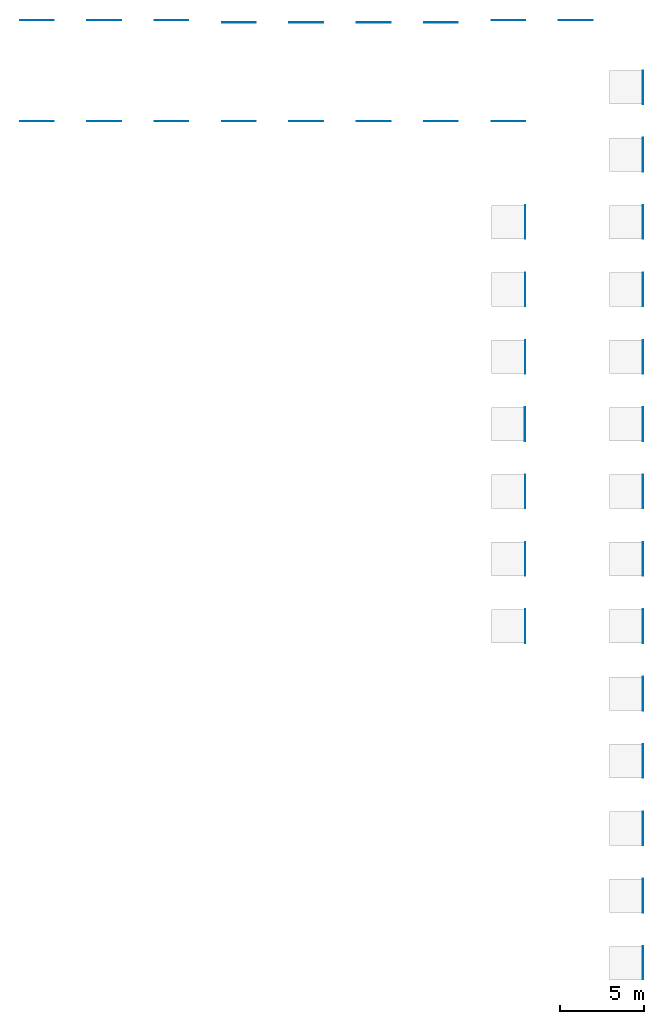
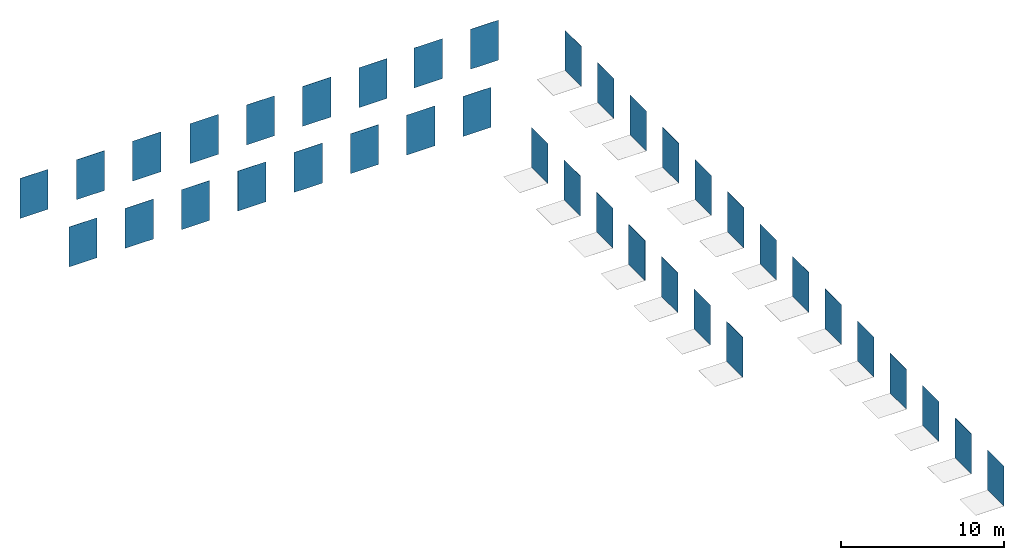
# One storey, part 1 of 2: 38 walls.
"""IFC2X3 building model written with IfcOpenShell, lengths in millimetres."""

from ifc_helpers import new_model, entity, si_unit, converted_unit, derived_unit, direction, frame, frame_2d, origin, place, context, subcontext, project, spatial, rectangle, extrude, material, layer, layer_set, layer_usage, type_object, element, save


model = new_model("IFC2X3")

# Units and contexts
model_context = context("Model", 3, precision=0.01, world=origin(), true_north=direction((6.12303176911189e-17, 1.0)))
body_context = subcontext(model_context, "Body", "Model", "MODEL_VIEW")
ifc_project = project(units=[si_unit("LENGTHUNIT", "METRE", prefix="MILLI"), si_unit("AREAUNIT", "SQUARE_METRE"), si_unit("VOLUMEUNIT", "CUBIC_METRE"), converted_unit("PLANEANGLEUNIT", "DEGREE", entity("IfcRatioMeasure", 0.0174532925199433), si_unit("PLANEANGLEUNIT", "RADIAN"), dimensions=[0, 0, 0, 0, 0, 0, 0]), si_unit("MASSUNIT", "GRAM", prefix="KILO"), derived_unit("MASSDENSITYUNIT", [(si_unit("MASSUNIT", "GRAM", prefix="KILO"), 1), (si_unit("LENGTHUNIT", "METRE"), -3)]), si_unit("TIMEUNIT", "SECOND"), si_unit("FREQUENCYUNIT", "HERTZ"), si_unit("THERMODYNAMICTEMPERATUREUNIT", "DEGREE_CELSIUS"), derived_unit("THERMALTRANSMITTANCEUNIT", [(si_unit("MASSUNIT", "GRAM", prefix="KILO"), 1), (si_unit("THERMODYNAMICTEMPERATUREUNIT", "KELVIN"), -1), (si_unit("TIMEUNIT", "SECOND"), -3)]), derived_unit("VOLUMETRICFLOWRATEUNIT", [(si_unit("LENGTHUNIT", "METRE"), 3), (si_unit("TIMEUNIT", "SECOND"), -1)]), si_unit("ELECTRICCURRENTUNIT", "AMPERE"), si_unit("ELECTRICVOLTAGEUNIT", "VOLT"), si_unit("POWERUNIT", "WATT"), si_unit("FORCEUNIT", "NEWTON", prefix="KILO"), si_unit("ILLUMINANCEUNIT", "LUX"), si_unit("LUMINOUSFLUXUNIT", "LUMEN"), si_unit("LUMINOUSINTENSITYUNIT", "CANDELA"), derived_unit("USERDEFINED", [(si_unit("MASSUNIT", "GRAM", prefix="KILO"), -1), (si_unit("LENGTHUNIT", "METRE"), -2), (si_unit("TIMEUNIT", "SECOND"), 3), (si_unit("LUMINOUSFLUXUNIT", "LUMEN"), 1)]), derived_unit("LINEARVELOCITYUNIT", [(si_unit("LENGTHUNIT", "METRE"), 1), (si_unit("TIMEUNIT", "SECOND"), -1)]), si_unit("PRESSUREUNIT", "PASCAL"), derived_unit("USERDEFINED", [(si_unit("LENGTHUNIT", "METRE"), -2), (si_unit("MASSUNIT", "GRAM", prefix="KILO"), 1), (si_unit("TIMEUNIT", "SECOND"), -2)])], contexts=[model_context])

# Site, building, storey
site_placement = place(None, origin())
site = spatial("IfcSite", under=ifc_project, at=site_placement, CompositionType="ELEMENT")
building_placement = place(site_placement, origin())
building = spatial("IfcBuilding", under=site, at=building_placement, CompositionType="ELEMENT")
storey_placement = place(building_placement, origin())
storey = spatial("IfcBuildingStorey", under=building, at=storey_placement, Name="Level 1", CompositionType="ELEMENT", Elevation=0.0)

# Walls
ifc_material_1 = material()
ifc_layer_1 = layer(ifc_material_1, 10.5)
ifc_layer_set_1 = layer_set([ifc_layer_1])
ifc_layer_usage_1 = layer_usage(ifc_layer_set_1, "AXIS2", "POSITIVE", -5.25)
wall_type_1 = type_object("IfcWallType", PredefinedType="STANDARD", material=ifc_layer_set_1)
wall_1_placement = place(storey_placement, frame((3521.82742659013, -2501.98267476882, 0.0), z_axis=(0.0, 0.0, 1.0), x_axis=(0.0, -1.0, 0.0)))
element("IfcWallStandardCase", 1, at=wall_1_placement, inside=storey, type_object=wall_type_1, material=ifc_layer_usage_1, context=body_context, shape_type="SweptSolid", body=[
    extrude(rectangle(XDim=2000.0, YDim=10.4999999999998, at=frame_2d((1000.0, 7.54951656745106e-15), x_axis=(-1.0, 0.0))), origin(), (0.0, 0.0, 1.0), 3000.00000000014),
])
ifc_material_2 = material()
ifc_layer_2 = layer(ifc_material_2, 10.5)
ifc_layer_set_2 = layer_set([ifc_layer_2])
ifc_layer_usage_2 = layer_usage(ifc_layer_set_2, "AXIS2", "POSITIVE", -5.25)
wall_type_2 = type_object("IfcWallType", PredefinedType="STANDARD", material=ifc_layer_set_2)
wall_2_placement = place(storey_placement, frame((3521.82742659012, -6501.98267476882, 0.0), z_axis=(0.0, 0.0, 1.0), x_axis=(0.0, -1.0, 0.0)))
element("IfcWallStandardCase", 2, at=wall_2_placement, inside=storey, type_object=wall_type_2, material=ifc_layer_usage_2, context=body_context, shape_type="SweptSolid", body=[
    extrude(rectangle(XDim=2000.0, YDim=10.4999999999998, at=frame_2d((1000.0, 7.54951656745106e-15), x_axis=(-1.0, 0.0))), origin(), (0.0, 0.0, 1.0), 3000.00000000014),
])
ifc_material_3 = material()
ifc_layer_3 = layer(ifc_material_3, 10.5)
ifc_layer_set_3 = layer_set([ifc_layer_3])
ifc_layer_usage_3 = layer_usage(ifc_layer_set_3, "AXIS2", "POSITIVE", -5.25)
wall_type_3 = type_object("IfcWallType", PredefinedType="STANDARD", material=ifc_layer_set_3)
wall_3_placement = place(storey_placement, frame((3521.82742659014, 5498.01732523118, 0.0), z_axis=(0.0, 0.0, 1.0), x_axis=(0.0, -1.0, 0.0)))
element("IfcWallStandardCase", 3, at=wall_3_placement, inside=storey, type_object=wall_type_3, material=ifc_layer_usage_3, context=body_context, shape_type="SweptSolid", body=[
    extrude(rectangle(XDim=2000.0, YDim=10.4999999999998, at=frame_2d((1000.0, 7.54951656745106e-15), x_axis=(-1.0, 0.0))), origin(), (0.0, 0.0, 1.0), 3000.00000000014),
])
ifc_material_4 = material()
ifc_layer_4 = layer(ifc_material_4, 10.5)
ifc_layer_set_4 = layer_set([ifc_layer_4])
ifc_layer_usage_4 = layer_usage(ifc_layer_set_4, "AXIS2", "POSITIVE", -5.25)
wall_type_4 = type_object("IfcWallType", PredefinedType="STANDARD", material=ifc_layer_set_4)
wall_4_placement = place(storey_placement, frame((3521.82742659014, 1498.01732523118, 0.0), z_axis=(0.0, 0.0, 1.0), x_axis=(0.0, -1.0, 0.0)))
element("IfcWallStandardCase", 4, at=wall_4_placement, inside=storey, type_object=wall_type_4, material=ifc_layer_usage_4, context=body_context, shape_type="SweptSolid", body=[
    extrude(rectangle(XDim=2000.0, YDim=10.4999999999998, at=frame_2d((1000.0, 7.54951656745106e-15), x_axis=(-1.0, 0.0))), origin(), (0.0, 0.0, 1.0), 3000.00000000014),
])
ifc_material_5 = material()
ifc_layer_5 = layer(ifc_material_5, 10.5)
ifc_layer_set_5 = layer_set([ifc_layer_5])
ifc_layer_usage_5 = layer_usage(ifc_layer_set_5, "AXIS2", "POSITIVE", -5.25)
wall_type_5 = type_object("IfcWallType", PredefinedType="STANDARD", material=ifc_layer_set_5)
wall_5_placement = place(storey_placement, frame((3521.82742659012, -10501.9826747688, 0.0), z_axis=(0.0, 0.0, 1.0), x_axis=(0.0, -1.0, 0.0)))
element("IfcWallStandardCase", 5, at=wall_5_placement, inside=storey, type_object=wall_type_5, material=ifc_layer_usage_5, context=body_context, shape_type="SweptSolid", body=[
    extrude(rectangle(XDim=2000.0, YDim=10.4999999999998, at=frame_2d((1000.0, 7.54951656745106e-15), x_axis=(-1.0, 0.0))), origin(), (0.0, 0.0, 1.0), 3000.00000000014),
])
ifc_material_6 = material()
ifc_layer_6 = layer(ifc_material_6, 10.5)
ifc_layer_set_6 = layer_set([ifc_layer_6])
ifc_layer_usage_6 = layer_usage(ifc_layer_set_6, "AXIS2", "POSITIVE", -5.25)
wall_type_6 = type_object("IfcWallType", PredefinedType="STANDARD", material=ifc_layer_set_6)
wall_6_placement = place(storey_placement, frame((3521.82742659011, -14501.9826747688, 0.0), z_axis=(0.0, 0.0, 1.0), x_axis=(0.0, -1.0, 0.0)))
element("IfcWallStandardCase", 6, at=wall_6_placement, inside=storey, type_object=wall_type_6, material=ifc_layer_usage_6, context=body_context, shape_type="SweptSolid", body=[
    extrude(rectangle(XDim=2000.0, YDim=10.4999999999998, at=frame_2d((1000.0, 7.54951656745106e-15), x_axis=(-1.0, 0.0))), origin(), (0.0, 0.0, 1.0), 3000.00000000014),
])
ifc_material_7 = material()
ifc_layer_7 = layer(ifc_material_7, 11.5)
ifc_layer_set_7 = layer_set([ifc_layer_7])
ifc_layer_usage_7 = layer_usage(ifc_layer_set_7, "AXIS2", "POSITIVE", -5.75)
wall_type_7 = type_object("IfcWallType", PredefinedType="STANDARD", material=ifc_layer_set_7)
wall_7_placement = place(storey_placement, frame((3521.32742659011, -18501.9826747688, 0.0), z_axis=(0.0, 0.0, 1.0), x_axis=(0.0, -1.0, 0.0)))
element("IfcWallStandardCase", 7, at=wall_7_placement, inside=storey, type_object=wall_type_7, material=ifc_layer_usage_7, context=body_context, shape_type="SweptSolid", body=[
    extrude(rectangle(XDim=2000.0, YDim=11.4999999999996, at=frame_2d((1000.0, 7.54951656745106e-15), x_axis=(-1.0, 0.0))), origin(), (0.0, 0.0, 1.0), 3000.00000000014),
])
ifc_material_8 = material()
ifc_layer_8 = layer(ifc_material_8, 11.5)
ifc_layer_set_8 = layer_set([ifc_layer_8])
ifc_layer_usage_8 = layer_usage(ifc_layer_set_8, "AXIS2", "POSITIVE", -5.75)
wall_type_8 = type_object("IfcWallType", PredefinedType="STANDARD", material=ifc_layer_set_8)
wall_8_placement = place(storey_placement, frame((3521.3274265901, -22501.9826747688, 0.0), z_axis=(0.0, 0.0, 1.0), x_axis=(0.0, -1.0, 0.0)))
element("IfcWallStandardCase", 8, at=wall_8_placement, inside=storey, type_object=wall_type_8, material=ifc_layer_usage_8, context=body_context, shape_type="SweptSolid", body=[
    extrude(rectangle(XDim=2000.0, YDim=11.4999999999996, at=frame_2d((1000.0, 7.54951656745106e-15), x_axis=(-1.0, 0.0))), origin(), (0.0, 0.0, 1.0), 3000.00000000014),
])
ifc_material_9 = material()
ifc_layer_9 = layer(ifc_material_9, 11.5)
ifc_layer_set_9 = layer_set([ifc_layer_9])
ifc_layer_usage_9 = layer_usage(ifc_layer_set_9, "AXIS2", "POSITIVE", -5.75)
wall_type_9 = type_object("IfcWallType", PredefinedType="STANDARD", material=ifc_layer_set_9)
wall_9_placement = place(storey_placement, frame((3521.32742659009, -26501.9826747688, 0.0), z_axis=(0.0, 0.0, 1.0), x_axis=(0.0, -1.0, 0.0)))
element("IfcWallStandardCase", 9, at=wall_9_placement, inside=storey, type_object=wall_type_9, material=ifc_layer_usage_9, context=body_context, shape_type="SweptSolid", body=[
    extrude(rectangle(XDim=2000.0, YDim=11.4999999999996, at=frame_2d((1000.0, 7.54951656745106e-15), x_axis=(-1.0, 0.0))), origin(), (0.0, 0.0, 1.0), 3000.00000000014),
])
ifc_material_10 = material()
ifc_layer_10 = layer(ifc_material_10, 11.5)
ifc_layer_set_10 = layer_set([ifc_layer_10])
ifc_layer_usage_10 = layer_usage(ifc_layer_set_10, "AXIS2", "POSITIVE", -5.75)
wall_type_10 = type_object("IfcWallType", PredefinedType="STANDARD", material=ifc_layer_set_10)
wall_10_placement = place(storey_placement, frame((3521.32742659009, -30501.9826747688, 0.0), z_axis=(0.0, 0.0, 1.0), x_axis=(0.0, -1.0, 0.0)))
element("IfcWallStandardCase", 10, at=wall_10_placement, inside=storey, type_object=wall_type_10, material=ifc_layer_usage_10, context=body_context, shape_type="SweptSolid", body=[
    extrude(rectangle(XDim=2000.0, YDim=11.4999999999996, at=frame_2d((1000.0, 7.54951656745106e-15), x_axis=(-1.0, 0.0))), origin(), (0.0, 0.0, 1.0), 3000.00000000014),
])
ifc_material_11 = material()
ifc_layer_11 = layer(ifc_material_11, 9.4)
ifc_layer_set_11 = layer_set([ifc_layer_11])
ifc_layer_usage_11 = layer_usage(ifc_layer_set_11, "AXIS2", "POSITIVE", -4.7)
wall_type_11 = type_object("IfcWallType", PredefinedType="STANDARD", material=ifc_layer_set_11)
wall_11_placement = place(storey_placement, frame((3522.37742659008, -34501.9826747688, 0.0), z_axis=(0.0, 0.0, 1.0), x_axis=(0.0, -1.0, 0.0)))
element("IfcWallStandardCase", 11, at=wall_11_placement, inside=storey, type_object=wall_type_11, material=ifc_layer_usage_11, context=body_context, shape_type="SweptSolid", body=[
    extrude(rectangle(XDim=2000.0, YDim=9.40000000000003, at=frame_2d((1000.0, 7.54951656745106e-15), x_axis=(-1.0, 0.0))), origin(), (0.0, 0.0, 1.0), 3000.00000000014),
])
ifc_material_12 = material()
ifc_layer_12 = layer(ifc_material_12, 9.4)
ifc_layer_set_12 = layer_set([ifc_layer_12])
ifc_layer_usage_12 = layer_usage(ifc_layer_set_12, "AXIS2", "POSITIVE", -4.7)
wall_type_12 = type_object("IfcWallType", PredefinedType="STANDARD", material=ifc_layer_set_12)
wall_12_placement = place(storey_placement, frame((3522.37742659007, -38501.9826747688, 0.0), z_axis=(0.0, 0.0, 1.0), x_axis=(0.0, -1.0, 0.0)))
element("IfcWallStandardCase", 12, at=wall_12_placement, inside=storey, type_object=wall_type_12, material=ifc_layer_usage_12, context=body_context, shape_type="SweptSolid", body=[
    extrude(rectangle(XDim=2000.0, YDim=9.40000000000003, at=frame_2d((999.999999999998, 7.54951656745106e-15), x_axis=(-1.0, 0.0))), origin(), (0.0, 0.0, 1.0), 3000.00000000014),
])
ifc_material_13 = material()
ifc_layer_13 = layer(ifc_material_13, 9.4)
ifc_layer_set_13 = layer_set([ifc_layer_13])
ifc_layer_usage_13 = layer_usage(ifc_layer_set_13, "AXIS2", "POSITIVE", -4.7)
wall_type_13 = type_object("IfcWallType", PredefinedType="STANDARD", material=ifc_layer_set_13)
wall_13_placement = place(storey_placement, frame((3522.37742659007, -42501.9826747688, 0.0), z_axis=(0.0, 0.0, 1.0), x_axis=(0.0, -1.0, 0.0)))
element("IfcWallStandardCase", 13, at=wall_13_placement, inside=storey, type_object=wall_type_13, material=ifc_layer_usage_13, context=body_context, shape_type="SweptSolid", body=[
    extrude(rectangle(XDim=2000.0, YDim=9.40000000000003, at=frame_2d((1000.0, 7.54951656745106e-15), x_axis=(-1.0, 0.0))), origin(), (0.0, 0.0, 1.0), 3000.00000000014),
])
ifc_material_14 = material()
ifc_layer_14 = layer(ifc_material_14, 10.5)
ifc_layer_set_14 = layer_set([ifc_layer_14])
ifc_layer_usage_14 = layer_usage(ifc_layer_set_14, "AXIS2", "POSITIVE", -5.25)
wall_type_14 = type_object("IfcWallType", PredefinedType="STANDARD", material=ifc_layer_set_14)
wall_14_placement = place(storey_placement, frame((3521.82742659006, -46501.9826747688, 0.0), z_axis=(0.0, 0.0, 1.0), x_axis=(0.0, -1.0, 0.0)))
element("IfcWallStandardCase", 14, at=wall_14_placement, inside=storey, type_object=wall_type_14, material=ifc_layer_usage_14, context=body_context, shape_type="SweptSolid", body=[
    extrude(rectangle(XDim=2000.0, YDim=10.4999999999998, at=frame_2d((1000.0, 7.54951656745106e-15), x_axis=(-1.0, 0.0))), origin(), (0.0, 0.0, 1.0), 3000.00000000014),
])
ifc_material_15 = material()
ifc_layer_15 = layer(ifc_material_15, 10.0)
ifc_layer_set_15 = layer_set([ifc_layer_15])
ifc_layer_usage_15 = layer_usage(ifc_layer_set_15, "AXIS2", "POSITIVE", -5.0)
wall_type_15 = type_object("IfcWallType", PredefinedType="STANDARD", material=ifc_layer_set_15)
wall_15_placement = place(storey_placement, frame((-3477.92257340986, -2501.98267476881, 0.0), z_axis=(0.0, 0.0, 1.0), x_axis=(0.0, -1.0, 0.0)))
element("IfcWallStandardCase", 15, at=wall_15_placement, inside=storey, type_object=wall_type_15, material=ifc_layer_usage_15, context=body_context, shape_type="SweptSolid", body=[
    extrude(rectangle(XDim=2000.0, YDim=9.99999999999989, at=frame_2d((1000.0, 7.54951656745106e-15), x_axis=(-1.0, 0.0))), origin(), (0.0, 0.0, 1.0), 3000.00000000014),
])
ifc_material_16 = material(Name="333x592mm_Dark-Gray")
ifc_layer_16 = layer(ifc_material_16, 8.6)
ifc_layer_set_16 = layer_set([ifc_layer_16], Name="Basic Wall:RevestimientoVertical_Dark_Gray-333x592mm")
ifc_layer_usage_16 = layer_usage(ifc_layer_set_16, "AXIS2", "POSITIVE", -4.3)
wall_type_16 = type_object("IfcWallType", Name="Basic Wall:RevestimientoVertical_Dark_Gray-333x592mm", PredefinedType="STANDARD", material=ifc_layer_set_16)
wall_16_placement = place(storey_placement, frame((-33472.9225734099, 8493.71732523128, 0.0)))
element("IfcWallStandardCase", 16, at=wall_16_placement, inside=storey, type_object=wall_type_16, material=ifc_layer_usage_16, Name="Basic Wall:RevestimientoVertical_Dark_Gray-333x592mm", ObjectType="Basic Wall:RevestimientoVertical_Dark_Gray-333x592mm", context=body_context, shape_type="SweptSolid", body=[
    extrude(rectangle(XDim=2000.0, YDim=8.60000000000021, at=frame_2d((1000.0, -2.48689957516035e-13), x_axis=(-1.0, 0.0))), origin(), (0.0, 0.0, 1.0), 3000.00000000014),
])
ifc_material_17 = material()
ifc_layer_17 = layer(ifc_material_17, 10.0)
ifc_layer_set_17 = layer_set([ifc_layer_17])
ifc_layer_usage_17 = layer_usage(ifc_layer_set_17, "AXIS2", "POSITIVE", -5.0)
wall_type_17 = type_object("IfcWallType", PredefinedType="STANDARD", material=ifc_layer_set_17)
wall_17_placement = place(storey_placement, frame((-3477.92257340986, -6501.9826747688, 0.0), z_axis=(0.0, 0.0, 1.0), x_axis=(0.0, -1.0, 0.0)))
element("IfcWallStandardCase", 17, at=wall_17_placement, inside=storey, type_object=wall_type_17, material=ifc_layer_usage_17, context=body_context, shape_type="SweptSolid", body=[
    extrude(rectangle(XDim=2000.0, YDim=9.99999999999989, at=frame_2d((1000.0, 7.54951656745106e-15), x_axis=(-1.0, 0.0))), origin(), (0.0, 0.0, 1.0), 3000.00000000014),
])
ifc_material_18 = material()
ifc_layer_18 = layer(ifc_material_18, 9.4)
ifc_layer_set_18 = layer_set([ifc_layer_18])
ifc_layer_usage_18 = layer_usage(ifc_layer_set_18, "AXIS2", "POSITIVE", -4.7)
wall_type_18 = type_object("IfcWallType", PredefinedType="STANDARD", material=ifc_layer_set_18)
wall_18_placement = place(storey_placement, frame((-3477.62257340986, -10501.9826747688, 0.0), z_axis=(0.0, 0.0, 1.0), x_axis=(0.0, -1.0, 0.0)))
element("IfcWallStandardCase", 18, at=wall_18_placement, inside=storey, type_object=wall_type_18, material=ifc_layer_usage_18, context=body_context, shape_type="SweptSolid", body=[
    extrude(rectangle(XDim=2000.0, YDim=9.40000000000003, at=frame_2d((1000.0, 7.54951656745106e-15), x_axis=(-1.0, 0.0))), origin(), (0.0, 0.0, 1.0), 3000.00000000014),
])
ifc_material_19 = material()
ifc_layer_19 = layer(ifc_material_19, 40.0)
ifc_layer_set_19 = layer_set([ifc_layer_19])
ifc_layer_usage_19 = layer_usage(ifc_layer_set_19, "AXIS2", "POSITIVE", -20.0)
wall_type_19 = type_object("IfcWallType", PredefinedType="STANDARD", material=ifc_layer_set_19)
wall_19_placement = place(storey_placement, frame((-3492.92257340986, -14501.9826747688, 0.0), z_axis=(0.0, 0.0, 1.0), x_axis=(0.0, -1.0, 0.0)))
element("IfcWallStandardCase", 19, at=wall_19_placement, inside=storey, type_object=wall_type_19, material=ifc_layer_usage_19, context=body_context, shape_type="SweptSolid", body=[
    extrude(rectangle(XDim=2000.0, YDim=39.9999999999996, at=frame_2d((1000.0, 8.88178419700125e-15), x_axis=(-1.0, 0.0))), origin(), (0.0, 0.0, 1.0), 3000.00000000014),
])
ifc_material_20 = material()
ifc_layer_20 = layer(ifc_material_20, 9.4)
ifc_layer_set_20 = layer_set([ifc_layer_20])
ifc_layer_usage_20 = layer_usage(ifc_layer_set_20, "AXIS2", "POSITIVE", -4.7)
wall_type_20 = type_object("IfcWallType", PredefinedType="STANDARD", material=ifc_layer_set_20)
wall_20_placement = place(storey_placement, frame((-3477.62257340986, -18501.9826747688, 0.0), z_axis=(0.0, 0.0, 1.0), x_axis=(0.0, -1.0, 0.0)))
element("IfcWallStandardCase", 20, at=wall_20_placement, inside=storey, type_object=wall_type_20, material=ifc_layer_usage_20, context=body_context, shape_type="SweptSolid", body=[
    extrude(rectangle(XDim=2000.0, YDim=9.40000000000003, at=frame_2d((1000.0, 7.54951656745106e-15), x_axis=(-1.0, 0.0))), origin(), (0.0, 0.0, 1.0), 3000.00000000014),
])
ifc_material_21 = material()
ifc_layer_21 = layer(ifc_material_21, 10.0)
ifc_layer_set_21 = layer_set([ifc_layer_21])
ifc_layer_usage_21 = layer_usage(ifc_layer_set_21, "AXIS2", "POSITIVE", -5.0)
wall_type_21 = type_object("IfcWallType", PredefinedType="STANDARD", material=ifc_layer_set_21)
wall_21_placement = place(storey_placement, frame((-3477.92257340986, -22501.9826747688, 0.0), z_axis=(0.0, 0.0, 1.0), x_axis=(0.0, -1.0, 0.0)))
element("IfcWallStandardCase", 21, at=wall_21_placement, inside=storey, type_object=wall_type_21, material=ifc_layer_usage_21, context=body_context, shape_type="SweptSolid", body=[
    extrude(rectangle(XDim=2000.0, YDim=9.99999999999989, at=frame_2d((1000.0, 7.54951656745106e-15), x_axis=(-1.0, 0.0))), origin(), (0.0, 0.0, 1.0), 3000.00000000014),
])
ifc_material_22 = material()
ifc_layer_22 = layer(ifc_material_22, 9.4)
ifc_layer_set_22 = layer_set([ifc_layer_22])
ifc_layer_usage_22 = layer_usage(ifc_layer_set_22, "AXIS2", "POSITIVE", -4.7)
wall_type_22 = type_object("IfcWallType", PredefinedType="STANDARD", material=ifc_layer_set_22)
wall_22_placement = place(storey_placement, frame((-3477.62257340986, -26501.9826747688, 0.0), z_axis=(0.0, 0.0, 1.0), x_axis=(0.0, -1.0, 0.0)))
element("IfcWallStandardCase", 22, at=wall_22_placement, inside=storey, type_object=wall_type_22, material=ifc_layer_usage_22, context=body_context, shape_type="SweptSolid", body=[
    extrude(rectangle(XDim=2000.0, YDim=9.40000000000003, at=frame_2d((1000.0, 7.54951656745106e-15), x_axis=(-1.0, 0.0))), origin(), (0.0, 0.0, 1.0), 3000.00000000014),
])
ifc_material_23 = material(Name="333x592mm_White")
ifc_layer_23 = layer(ifc_material_23, 9.6)
ifc_layer_set_23 = layer_set([ifc_layer_23], Name="Basic Wall:RevestimientoVertical_White-333x592mm")
ifc_layer_usage_23 = layer_usage(ifc_layer_set_23, "AXIS2", "POSITIVE", -4.8)
wall_type_23 = type_object("IfcWallType", Name="Basic Wall:RevestimientoVertical_White-333x592mm", PredefinedType="STANDARD", material=ifc_layer_set_23)
wall_23_placement = place(storey_placement, frame((-29472.9225734099, 8494.21732523126, 0.0)))
element("IfcWallStandardCase", 23, at=wall_23_placement, inside=storey, type_object=wall_type_23, material=ifc_layer_usage_23, Name="Basic Wall:RevestimientoVertical_White-333x592mm", ObjectType="Basic Wall:RevestimientoVertical_White-333x592mm", context=body_context, shape_type="SweptSolid", body=[
    extrude(rectangle(XDim=2000.0, YDim=9.59999999999998, at=frame_2d((1000.0, -2.48689957516035e-13), x_axis=(-1.0, 0.0))), origin(), (0.0, 0.0, 1.0), 3000.00000000014),
])
ifc_material_24 = material(Name="333x1000mm_Old-Beige")
ifc_layer_24 = layer(ifc_material_24, 12.0)
ifc_layer_set_24 = layer_set([ifc_layer_24], Name="Basic Wall:RevestimientoVertical_Old_Beige-333x1000mm")
ifc_layer_usage_24 = layer_usage(ifc_layer_set_24, "AXIS2", "POSITIVE", -6.0)
wall_type_24 = type_object("IfcWallType", Name="Basic Wall:RevestimientoVertical_Old_Beige-333x1000mm", PredefinedType="STANDARD", material=ifc_layer_set_24)
wall_24_placement = place(storey_placement, frame((-3472.92257340986, 2482.81732523118, 0.0), z_axis=(0.0, 0.0, 1.0), x_axis=(-1.0, 0.0, 0.0)))
element("IfcWallStandardCase", 24, at=wall_24_placement, inside=storey, type_object=wall_type_24, material=ifc_layer_usage_24, Name="Basic Wall:RevestimientoVertical_Old_Beige-333x1000mm", ObjectType="Basic Wall:RevestimientoVertical_Old_Beige-333x1000mm", context=body_context, shape_type="SweptSolid", body=[
    extrude(rectangle(XDim=2000.0, YDim=12.0000000000005, at=frame_2d((1000.0, 5.90638649100583e-14), x_axis=(-1.0, 0.0))), origin(), (0.0, 0.0, 1.0), 3000.00000000014),
])
ifc_material_25 = material(Name="333x1000mm_Old-Dark-Gray")
ifc_layer_25 = layer(ifc_material_25, 12.0)
ifc_layer_set_25 = layer_set([ifc_layer_25], Name="Basic Wall:RevestimientoVertical_Old_Dark_Gray-333x1000mm")
ifc_layer_usage_25 = layer_usage(ifc_layer_set_25, "AXIS2", "POSITIVE", -6.0)
wall_type_25 = type_object("IfcWallType", Name="Basic Wall:RevestimientoVertical_Old_Dark_Gray-333x1000mm", PredefinedType="STANDARD", material=ifc_layer_set_25)
wall_25_placement = place(storey_placement, frame((-7472.92257340986, 2482.81732523122, 0.0), z_axis=(0.0, 0.0, 1.0), x_axis=(-1.0, 0.0, 0.0)))
element("IfcWallStandardCase", 25, at=wall_25_placement, inside=storey, type_object=wall_type_25, material=ifc_layer_usage_25, Name="Basic Wall:RevestimientoVertical_Old_Dark_Gray-333x1000mm", ObjectType="Basic Wall:RevestimientoVertical_Old_Dark_Gray-333x1000mm", context=body_context, shape_type="SweptSolid", body=[
    extrude(rectangle(XDim=2000.0, YDim=12.0000000000005, at=frame_2d((1000.0, 5.90638649100583e-14), x_axis=(-1.0, 0.0))), origin(), (0.0, 0.0, 1.0), 3000.00000000014),
])
ifc_material_26 = material(Name="333x1000mm_Old-Gray")
ifc_layer_26 = layer(ifc_material_26, 12.0)
ifc_layer_set_26 = layer_set([ifc_layer_26], Name="Basic Wall:RevestimientoVertical_Old_Gray-333x1000mm")
ifc_layer_usage_26 = layer_usage(ifc_layer_set_26, "AXIS2", "POSITIVE", -6.0)
wall_type_26 = type_object("IfcWallType", Name="Basic Wall:RevestimientoVertical_Old_Gray-333x1000mm", PredefinedType="STANDARD", material=ifc_layer_set_26)
wall_26_placement = place(storey_placement, frame((-11472.9225734099, 2482.81732523126, 0.0), z_axis=(0.0, 0.0, 1.0), x_axis=(-1.0, 0.0, 0.0)))
element("IfcWallStandardCase", 26, at=wall_26_placement, inside=storey, type_object=wall_type_26, material=ifc_layer_usage_26, Name="Basic Wall:RevestimientoVertical_Old_Gray-333x1000mm", ObjectType="Basic Wall:RevestimientoVertical_Old_Gray-333x1000mm", context=body_context, shape_type="SweptSolid", body=[
    extrude(rectangle(XDim=2000.0, YDim=12.0000000000005, at=frame_2d((1000.0, 5.90638649100583e-14), x_axis=(-1.0, 0.0))), origin(), (0.0, 0.0, 1.0), 3000.00000000014),
])
ifc_material_27 = material(Name="333x1000mm_Old-Natural")
ifc_layer_27 = layer(ifc_material_27, 12.0)
ifc_layer_set_27 = layer_set([ifc_layer_27], Name="Basic Wall:RevestimientoVertical_Old_Natural-333x1000mm")
ifc_layer_usage_27 = layer_usage(ifc_layer_set_27, "AXIS2", "POSITIVE", -6.0)
wall_type_27 = type_object("IfcWallType", Name="Basic Wall:RevestimientoVertical_Old_Natural-333x1000mm", PredefinedType="STANDARD", material=ifc_layer_set_27)
wall_27_placement = place(storey_placement, frame((-15472.9225734099, 2482.81732523132, 0.0), z_axis=(0.0, 0.0, 1.0), x_axis=(-1.0, 0.0, 0.0)))
element("IfcWallStandardCase", 27, at=wall_27_placement, inside=storey, type_object=wall_type_27, material=ifc_layer_usage_27, Name="Basic Wall:RevestimientoVertical_Old_Natural-333x1000mm", ObjectType="Basic Wall:RevestimientoVertical_Old_Natural-333x1000mm", context=body_context, shape_type="SweptSolid", body=[
    extrude(rectangle(XDim=2000.0, YDim=12.0000000000005, at=frame_2d((1000.0, 5.90638649100583e-14), x_axis=(-1.0, 0.0))), origin(), (0.0, 0.0, 1.0), 3000.00000000014),
])
ifc_material_28 = material(Name="333x1000mm_Old-White")
ifc_layer_28 = layer(ifc_material_28, 12.0)
ifc_layer_set_28 = layer_set([ifc_layer_28], Name="Basic Wall:RevestimientoVertical_Old_White-333x1000mm")
ifc_layer_usage_28 = layer_usage(ifc_layer_set_28, "AXIS2", "POSITIVE", -6.0)
wall_type_28 = type_object("IfcWallType", Name="Basic Wall:RevestimientoVertical_Old_White-333x1000mm", PredefinedType="STANDARD", material=ifc_layer_set_28)
wall_28_placement = place(storey_placement, frame((-19472.9225734099, 2482.81732523137, 0.0), z_axis=(0.0, 0.0, 1.0), x_axis=(-1.0, 0.0, 0.0)))
element("IfcWallStandardCase", 28, at=wall_28_placement, inside=storey, type_object=wall_type_28, material=ifc_layer_usage_28, Name="Basic Wall:RevestimientoVertical_Old_White-333x1000mm", ObjectType="Basic Wall:RevestimientoVertical_Old_White-333x1000mm", context=body_context, shape_type="SweptSolid", body=[
    extrude(rectangle(XDim=2000.0, YDim=12.0000000000005, at=frame_2d((1000.0, 5.90638649100583e-14), x_axis=(-1.0, 0.0))), origin(), (0.0, 0.0, 1.0), 3000.00000000014),
])
ifc_material_29 = material(Name="333x592mm_Old-Beige")
ifc_layer_29 = layer(ifc_material_29, 8.6)
ifc_layer_set_29 = layer_set([ifc_layer_29], Name="Basic Wall:RevestimientoVertical_Old_Beige-333x592mm")
ifc_layer_usage_29 = layer_usage(ifc_layer_set_29, "AXIS2", "POSITIVE", -4.3)
wall_type_29 = type_object("IfcWallType", Name="Basic Wall:RevestimientoVertical_Old_Beige-333x592mm", PredefinedType="STANDARD", material=ifc_layer_set_29)
wall_29_placement = place(storey_placement, frame((-23472.9225734099, 2481.1173252314, 0.0), z_axis=(0.0, 0.0, 1.0), x_axis=(-1.0, 0.0, 0.0)))
element("IfcWallStandardCase", 29, at=wall_29_placement, inside=storey, type_object=wall_type_29, material=ifc_layer_usage_29, Name="Basic Wall:RevestimientoVertical_Old_Beige-333x592mm", ObjectType="Basic Wall:RevestimientoVertical_Old_Beige-333x592mm", context=body_context, shape_type="SweptSolid", body=[
    extrude(rectangle(XDim=2000.0, YDim=8.60000000000021, at=frame_2d((1000.0, 5.90638649100583e-14), x_axis=(-1.0, 0.0))), origin(), (0.0, 0.0, 1.0), 3000.00000000014),
])
ifc_material_30 = material(Name="333x592mm_Old-Natural")
ifc_layer_30 = layer(ifc_material_30, 8.6)
ifc_layer_set_30 = layer_set([ifc_layer_30], Name="Basic Wall:RevestimientoVertical_Old_Natural-333x592mm")
ifc_layer_usage_30 = layer_usage(ifc_layer_set_30, "AXIS2", "POSITIVE", -4.3)
wall_type_30 = type_object("IfcWallType", Name="Basic Wall:RevestimientoVertical_Old_Natural-333x592mm", PredefinedType="STANDARD", material=ifc_layer_set_30)
wall_30_placement = place(storey_placement, frame((-27472.9225734099, 2481.11732523144, 0.0), z_axis=(0.0, 0.0, 1.0), x_axis=(-1.0, 0.0, 0.0)))
element("IfcWallStandardCase", 30, at=wall_30_placement, inside=storey, type_object=wall_type_30, material=ifc_layer_usage_30, Name="Basic Wall:RevestimientoVertical_Old_Natural-333x592mm", ObjectType="Basic Wall:RevestimientoVertical_Old_Natural-333x592mm", context=body_context, shape_type="SweptSolid", body=[
    extrude(rectangle(XDim=2000.0, YDim=8.60000000000021, at=frame_2d((1000.0, 5.90638649100583e-14), x_axis=(-1.0, 0.0))), origin(), (0.0, 0.0, 1.0), 3000.00000000014),
])
ifc_material_31 = material(Name="333x592mm_Old-White")
ifc_layer_31 = layer(ifc_material_31, 8.6)
ifc_layer_set_31 = layer_set([ifc_layer_31], Name="Basic Wall:RevestimientoVertical_Old_White-333x592mm")
ifc_layer_usage_31 = layer_usage(ifc_layer_set_31, "AXIS2", "POSITIVE", -4.3)
wall_type_31 = type_object("IfcWallType", Name="Basic Wall:RevestimientoVertical_Old_White-333x592mm", PredefinedType="STANDARD", material=ifc_layer_set_31)
wall_31_placement = place(storey_placement, frame((-31472.9225734099, 2481.11732523149, 0.0), z_axis=(0.0, 0.0, 1.0), x_axis=(-1.0, 0.0, 0.0)))
element("IfcWallStandardCase", 31, at=wall_31_placement, inside=storey, type_object=wall_type_31, material=ifc_layer_usage_31, Name="Basic Wall:RevestimientoVertical_Old_White-333x592mm", ObjectType="Basic Wall:RevestimientoVertical_Old_White-333x592mm", context=body_context, shape_type="SweptSolid", body=[
    extrude(rectangle(XDim=2000.0, YDim=8.60000000000021, at=frame_2d((1000.0, 5.90638649100583e-14), x_axis=(-1.0, 0.0))), origin(), (0.0, 0.0, 1.0), 3000.00000000014),
])
ifc_material_32 = material(Name="333x592mm_Beige")
ifc_layer_32 = layer(ifc_material_32, 8.6)
ifc_layer_set_32 = layer_set([ifc_layer_32], Name="Basic Wall:RevestimientoVertical_Beige-333x592mm")
ifc_layer_usage_32 = layer_usage(ifc_layer_set_32, "AXIS2", "NEGATIVE", 4.3)
wall_type_32 = type_object("IfcWallType", Name="Basic Wall:RevestimientoVertical_Beige-333x592mm", PredefinedType="STANDARD", material=ifc_layer_set_32)
wall_32_placement = place(storey_placement, frame((-21472.9225734099, 8353.51933842123, 0.0)))
element("IfcWallStandardCase", 32, at=wall_32_placement, inside=storey, type_object=wall_type_32, material=ifc_layer_usage_32, Name="Basic Wall:RevestimientoVertical_Beige-333x592mm", ObjectType="Basic Wall:RevestimientoVertical_Beige-333x592mm", context=body_context, shape_type="SweptSolid", body=[
    extrude(rectangle(XDim=2000.0, YDim=8.60000000000021, at=frame_2d((1000.0, 0.0), x_axis=(-1.0, 0.0))), origin(), (0.0, 0.0, 1.0), 2999.99999999994),
])
ifc_material_33 = material(Name="333x1000mm_White")
ifc_layer_33 = layer(ifc_material_33, 9.2)
ifc_layer_set_33 = layer_set([ifc_layer_33], Name="Basic Wall:RevestimientoVertical_White-333x1000mm")
ifc_layer_usage_33 = layer_usage(ifc_layer_set_33, "AXIS2", "NEGATIVE", 4.6)
wall_type_33 = type_object("IfcWallType", Name="Basic Wall:RevestimientoVertical_White-333x1000mm", PredefinedType="STANDARD", material=ifc_layer_set_33)
wall_33_placement = place(storey_placement, frame((-17472.9225734099, 8353.81933842121, 0.0)))
element("IfcWallStandardCase", 33, at=wall_33_placement, inside=storey, type_object=wall_type_33, material=ifc_layer_usage_33, Name="Basic Wall:RevestimientoVertical_White-333x1000mm", ObjectType="Basic Wall:RevestimientoVertical_White-333x1000mm", context=body_context, shape_type="SweptSolid", body=[
    extrude(rectangle(XDim=2000.0, YDim=9.20000000000007, at=frame_2d((1000.0, 0.0), x_axis=(-1.0, 0.0))), origin(), (0.0, 0.0, 1.0), 2999.99999999994),
])
ifc_material_34 = material(Name="333x1000mm_Natural")
ifc_layer_34 = layer(ifc_material_34, 9.2)
ifc_layer_set_34 = layer_set([ifc_layer_34], Name="Basic Wall:RevestimientoVertical_Natural-333x1000mm")
ifc_layer_usage_34 = layer_usage(ifc_layer_set_34, "AXIS2", "NEGATIVE", 4.6)
wall_type_34 = type_object("IfcWallType", Name="Basic Wall:RevestimientoVertical_Natural-333x1000mm", PredefinedType="STANDARD", material=ifc_layer_set_34)
wall_34_placement = place(storey_placement, frame((-13472.9225734099, 8353.8193384212, 0.0)))
element("IfcWallStandardCase", 34, at=wall_34_placement, inside=storey, type_object=wall_type_34, material=ifc_layer_usage_34, Name="Basic Wall:RevestimientoVertical_Natural-333x1000mm", ObjectType="Basic Wall:RevestimientoVertical_Natural-333x1000mm", context=body_context, shape_type="SweptSolid", body=[
    extrude(rectangle(XDim=2000.0, YDim=9.20000000000007, at=frame_2d((1000.0, 0.0), x_axis=(-1.0, 0.0))), origin(), (0.0, 0.0, 1.0), 2999.99999999994),
])
ifc_material_35 = material(Name="333x1000mm_Gray")
ifc_layer_35 = layer(ifc_material_35, 9.2)
ifc_layer_set_35 = layer_set([ifc_layer_35], Name="Basic Wall:RevestimientoVertical_Gray-333x1000mm")
ifc_layer_usage_35 = layer_usage(ifc_layer_set_35, "AXIS2", "NEGATIVE", 4.6)
wall_type_35 = type_object("IfcWallType", Name="Basic Wall:RevestimientoVertical_Gray-333x1000mm", PredefinedType="STANDARD", material=ifc_layer_set_35)
wall_35_placement = place(storey_placement, frame((-9472.92257340987, 8353.81933842119, 0.0)))
element("IfcWallStandardCase", 35, at=wall_35_placement, inside=storey, type_object=wall_type_35, material=ifc_layer_usage_35, Name="Basic Wall:RevestimientoVertical_Gray-333x1000mm", ObjectType="Basic Wall:RevestimientoVertical_Gray-333x1000mm", context=body_context, shape_type="SweptSolid", body=[
    extrude(rectangle(XDim=2000.0, YDim=9.20000000000007, at=frame_2d((1000.0, 0.0), x_axis=(-1.0, 0.0))), origin(), (0.0, 0.0, 1.0), 2999.99999999994),
])
ifc_material_36 = material(Name="333x1000mm_Gray_Dark")
ifc_layer_36 = layer(ifc_material_36, 9.2)
ifc_layer_set_36 = layer_set([ifc_layer_36], Name="Basic Wall:RevestimientoVertical_Dark_Gray-333x1000mm")
ifc_layer_usage_36 = layer_usage(ifc_layer_set_36, "AXIS2", "NEGATIVE", 4.6)
wall_type_36 = type_object("IfcWallType", Name="Basic Wall:RevestimientoVertical_Dark_Gray-333x1000mm", PredefinedType="STANDARD", material=ifc_layer_set_36)
wall_36_placement = place(storey_placement, frame((-5475.35926533348, 8493.41732523119, 0.0)))
element("IfcWallStandardCase", 36, at=wall_36_placement, inside=storey, type_object=wall_type_36, material=ifc_layer_usage_36, Name="Basic Wall:RevestimientoVertical_Dark_Gray-333x1000mm", ObjectType="Basic Wall:RevestimientoVertical_Dark_Gray-333x1000mm", context=body_context, shape_type="SweptSolid", body=[
    extrude(rectangle(XDim=2000.0, YDim=9.20000000000007, at=frame_2d((1000.0, 0.0), x_axis=(-1.0, 0.0))), origin(), (0.0, 0.0, 1.0), 2999.99999999994),
])
ifc_material_37 = material(Name="333x1000mm_Beige")
ifc_layer_37 = layer(ifc_material_37, 9.2)
ifc_layer_set_37 = layer_set([ifc_layer_37], Name="Basic Wall:RevestimientoVertical_Beige-333x1000mm")
ifc_layer_usage_37 = layer_usage(ifc_layer_set_37, "AXIS2", "NEGATIVE", 4.6)
wall_type_37 = type_object("IfcWallType", Name="Basic Wall:RevestimientoVertical_Beige-333x1000mm", PredefinedType="STANDARD", material=ifc_layer_set_37)
wall_37_placement = place(storey_placement, frame((-1475.35926533348, 8493.41732523118, 0.0)))
element("IfcWallStandardCase", 37, at=wall_37_placement, inside=storey, type_object=wall_type_37, material=ifc_layer_usage_37, Name="Basic Wall:RevestimientoVertical_Beige-333x1000mm", ObjectType="Basic Wall:RevestimientoVertical_Beige-333x1000mm", context=body_context, shape_type="SweptSolid", body=[
    extrude(rectangle(XDim=2000.0, YDim=9.20000000000007, at=frame_2d((1000.0, 0.0), x_axis=(-1.0, 0.0))), origin(), (0.0, 0.0, 1.0), 2999.99999999994),
])
ifc_material_38 = material(Name="333x592mm_Natural")
ifc_layer_38 = layer(ifc_material_38, 8.6)
ifc_layer_set_38 = layer_set([ifc_layer_38], Name="Basic Wall:RevestimientoVertical_Natural-333x592mm")
ifc_layer_usage_38 = layer_usage(ifc_layer_set_38, "AXIS2", "NEGATIVE", 4.3)
wall_type_38 = type_object("IfcWallType", Name="Basic Wall:RevestimientoVertical_Natural-333x592mm", PredefinedType="STANDARD", material=ifc_layer_set_38)
wall_38_placement = place(storey_placement, frame((-25472.9225734099, 8493.71732523125, 0.0)))
element("IfcWallStandardCase", 38, at=wall_38_placement, inside=storey, type_object=wall_type_38, material=ifc_layer_usage_38, Name="Basic Wall:RevestimientoVertical_Natural-333x592mm", ObjectType="Basic Wall:RevestimientoVertical_Natural-333x592mm", context=body_context, shape_type="SweptSolid", body=[
    extrude(rectangle(XDim=2000.0, YDim=8.60000000000021, at=frame_2d((1000.0, 0.0), x_axis=(-1.0, 0.0))), origin(), (0.0, 0.0, 1.0), 2999.99999999994),
])

save(model, "model.ifc")
